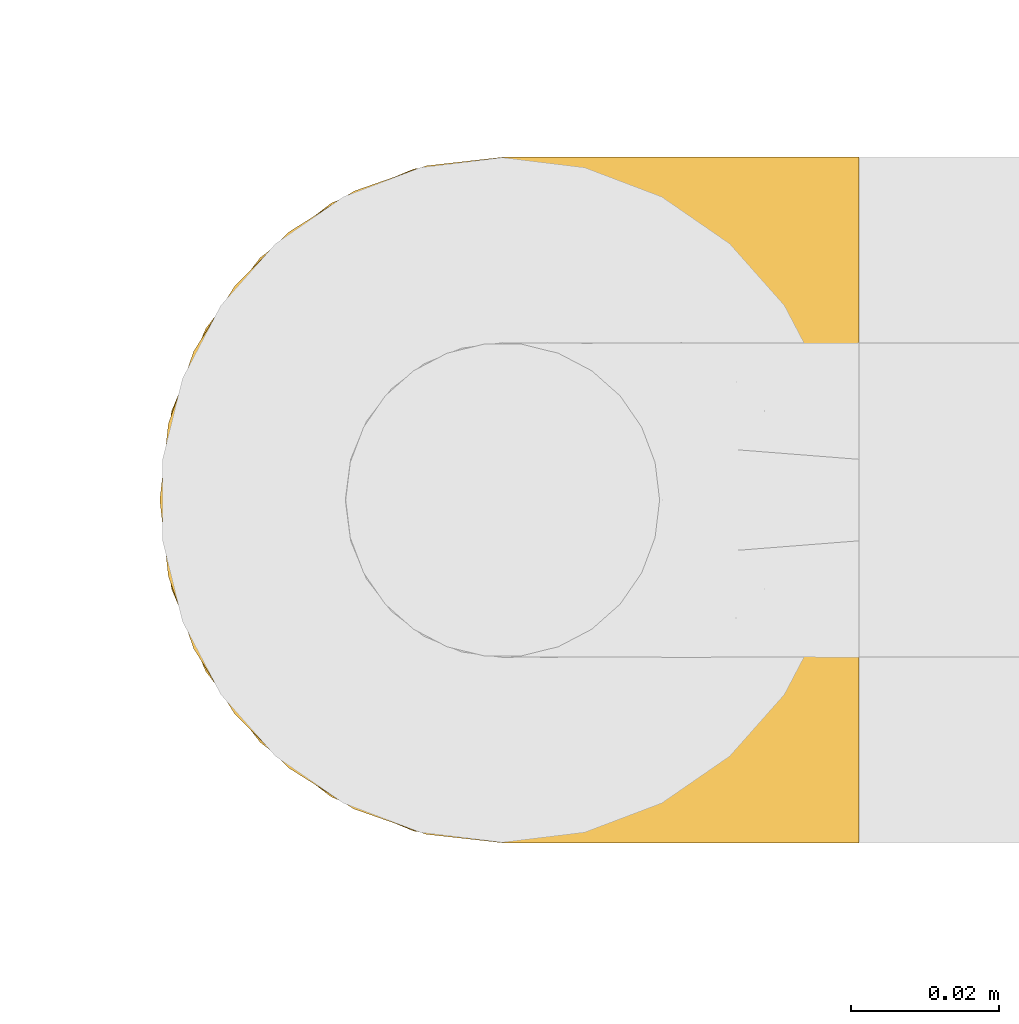
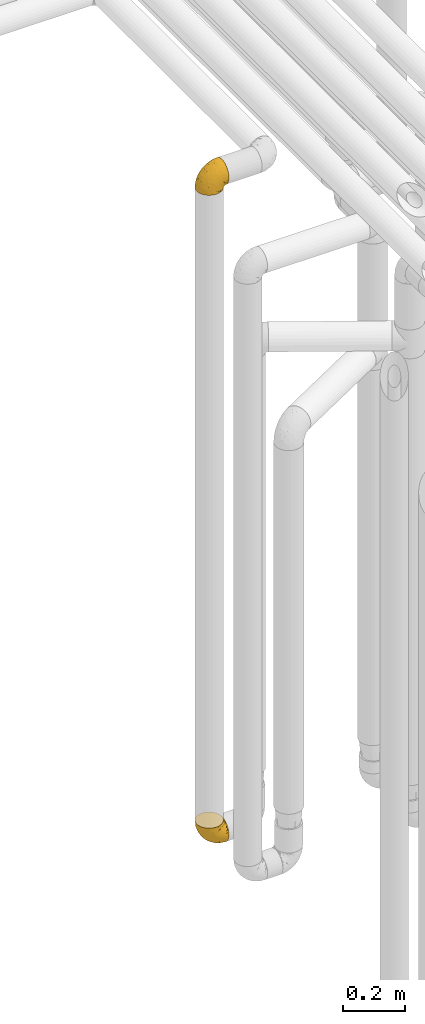
# One storey, part 176 of 827: 2 coverings.
"""IFC2X3 building model written with IfcOpenShell, lengths in millimetres."""

from ifc_helpers import new_model, entity, si_unit, converted_unit, derived_unit, direction, frame, origin, place, context, subcontext, project, spatial, faceted_brep, element, save


model = new_model("IFC2X3")

# Units and contexts
model_context = context("Model", 3, precision=0.01, world=origin(), true_north=direction((6.12303176911189e-17, 1.0)))
body_context = subcontext(model_context, "Body", "Model", "MODEL_VIEW")
ifc_project = project(units=[si_unit("LENGTHUNIT", "METRE", prefix="MILLI"), si_unit("AREAUNIT", "SQUARE_METRE"), si_unit("VOLUMEUNIT", "CUBIC_METRE"), converted_unit("PLANEANGLEUNIT", "DEGREE", entity("IfcRatioMeasure", 0.0174532925199433), si_unit("PLANEANGLEUNIT", "RADIAN"), dimensions=[0, 0, 0, 0, 0, 0, 0]), si_unit("MASSUNIT", "GRAM", prefix="KILO"), derived_unit("MASSDENSITYUNIT", [(si_unit("MASSUNIT", "GRAM", prefix="KILO"), 1), (si_unit("LENGTHUNIT", "METRE"), -3)]), derived_unit("MOMENTOFINERTIAUNIT", [(si_unit("LENGTHUNIT", "METRE"), 4)]), si_unit("TIMEUNIT", "SECOND"), si_unit("FREQUENCYUNIT", "HERTZ"), si_unit("THERMODYNAMICTEMPERATUREUNIT", "DEGREE_CELSIUS"), derived_unit("THERMALTRANSMITTANCEUNIT", [(si_unit("MASSUNIT", "GRAM", prefix="KILO"), 1), (si_unit("THERMODYNAMICTEMPERATUREUNIT", "KELVIN"), -1), (si_unit("TIMEUNIT", "SECOND"), -3)]), derived_unit("VOLUMETRICFLOWRATEUNIT", [(si_unit("LENGTHUNIT", "METRE"), 3), (si_unit("TIMEUNIT", "SECOND"), -1)]), derived_unit("MASSFLOWRATEUNIT", [(si_unit("MASSUNIT", "GRAM", prefix="KILO"), 1), (si_unit("TIMEUNIT", "SECOND"), -1)]), derived_unit("ROTATIONALFREQUENCYUNIT", [(si_unit("TIMEUNIT", "SECOND"), -1)]), si_unit("ELECTRICCURRENTUNIT", "AMPERE"), si_unit("ELECTRICVOLTAGEUNIT", "VOLT"), si_unit("POWERUNIT", "WATT"), si_unit("FORCEUNIT", "NEWTON", prefix="KILO"), si_unit("ILLUMINANCEUNIT", "LUX"), si_unit("LUMINOUSFLUXUNIT", "LUMEN"), si_unit("LUMINOUSINTENSITYUNIT", "CANDELA"), derived_unit("USERDEFINED", [(si_unit("MASSUNIT", "GRAM", prefix="KILO"), -1), (si_unit("LENGTHUNIT", "METRE"), -2), (si_unit("TIMEUNIT", "SECOND"), 3), (si_unit("LUMINOUSFLUXUNIT", "LUMEN"), 1)]), derived_unit("LINEARVELOCITYUNIT", [(si_unit("LENGTHUNIT", "METRE"), 1), (si_unit("TIMEUNIT", "SECOND"), -1)]), si_unit("PRESSUREUNIT", "PASCAL"), derived_unit("USERDEFINED", [(si_unit("LENGTHUNIT", "METRE"), -2), (si_unit("MASSUNIT", "GRAM", prefix="KILO"), 1), (si_unit("TIMEUNIT", "SECOND"), -2)]), derived_unit("LINEARFORCEUNIT", [(si_unit("MASSUNIT", "GRAM", prefix="KILO"), 1), (si_unit("LENGTHUNIT", "METRE"), 1), (si_unit("TIMEUNIT", "SECOND"), -2), (si_unit("LENGTHUNIT", "METRE"), -1)]), derived_unit("PLANARFORCEUNIT", [(si_unit("MASSUNIT", "GRAM", prefix="KILO"), 1), (si_unit("LENGTHUNIT", "METRE"), 1), (si_unit("TIMEUNIT", "SECOND"), -2), (si_unit("LENGTHUNIT", "METRE"), -2)])], contexts=[model_context])

# Site, building, storey
site_placement = place(None, origin())
site = spatial("IfcSite", under=ifc_project, at=site_placement, CompositionType="ELEMENT")
building_placement = place(site_placement, origin())
building = spatial("IfcBuilding", under=site, at=building_placement, CompositionType="ELEMENT")
storey_placement = place(building_placement, frame((0.0, 0.0, 28200.0)))
storey = spatial("IfcBuildingStorey", under=building, at=storey_placement, Name="08", CompositionType="ELEMENT", Elevation=28200.0)

# Coverings
covering_1_placement = place(storey_placement, frame((35072.24, 12958.41, 2950.4)))
element("IfcCovering", 1, at=covering_1_placement, inside=storey, Name=":ADSK_", ObjectType=":ADSK_", PredefinedType="INSULATION", context=body_context, shape_type="Brep", body=[
    faceted_brep([(18.98, 11.68, 1.6), (11.67, 19.0, 1.6), (6.17, 27.76, 1.6), (2.75, 37.52, 1.6), (1.6, 47.8, 1.6), (2.75, 58.08, 1.6), (6.17, 67.85, 1.6), (11.68, 76.61, 1.6), (19.0, 83.92, 1.6), (27.76, 89.42, 1.6), (37.52, 92.84, 1.6), (47.8, 94.0, 1.6), (51.94, 93.53, 1.6), (55.01, 93.18, 1.6), (58.08, 92.84, 1.6), (62.96, 91.13, 1.6), (67.85, 89.42, 1.6), (72.23, 86.66, 1.6), (76.61, 83.91, 1.6), (80.26, 80.25, 1.6), (83.92, 76.59, 1.6), (89.42, 67.83, 1.6), (91.13, 62.95, 1.6), (92.84, 58.07, 1.6), (94.0, 47.8, 1.6), (92.84, 37.51, 1.6), (91.13, 32.63, 1.6), (89.42, 27.74, 1.6), (83.91, 18.98, 1.6), (80.25, 15.33, 1.6), (76.59, 11.67, 1.6), (72.21, 8.92, 1.6), (67.83, 6.17, 1.6), (62.95, 4.46, 1.6), (58.07, 2.75, 1.6), (55.0, 2.41, 1.6), (51.94, 2.06, 1.6), (47.8, 1.6, 1.6), (37.51, 2.75, 1.6), (27.74, 6.17, 1.6), (95.8, 47.8, 3.4), (95.8, 59.75, 4.97), (95.8, 70.9, 9.58), (95.8, 75.68, 13.26), (95.8, 80.46, 16.93), (95.8, 84.13, 21.71), (95.8, 87.81, 26.5), (95.8, 90.11, 32.07), (95.8, 92.42, 37.64), (95.8, 92.9, 41.25), (95.8, 93.17, 43.34), (95.8, 93.45, 45.42), (95.8, 94.0, 49.6), (95.8, 92.42, 61.55), (95.8, 87.81, 72.7), (95.8, 80.46, 82.26), (95.8, 70.9, 89.61), (95.8, 59.75, 94.22), (95.8, 47.8, 95.8), (95.8, 35.84, 94.22), (95.8, 24.7, 89.61), (95.8, 15.13, 82.26), (95.8, 7.78, 72.7), (95.8, 3.17, 61.55), (95.8, 1.6, 49.6), (95.8, 2.14, 45.42), (95.8, 2.69, 41.25), (95.8, 3.17, 37.64), (95.8, 5.48, 32.07), (95.8, 7.78, 26.5), (95.8, 11.46, 21.71), (95.8, 15.13, 16.93), (95.8, 19.91, 13.26), (95.8, 24.7, 9.58), (95.8, 35.84, 4.97), (60.58, 23.61, 81.55), (74.11, 31.99, 90.4), (51.59, 35.87, 83.0), (66.69, 47.8, 91.18), (76.19, 40.43, 93.13), (84.43, 47.8, 94.0), (31.2, 31.83, 66.19), (42.88, 23.37, 70.92), (79.41, 21.41, 85.95), (60.7, 3.07, 49.74), (61.85, 1.6, 35.54), (65.75, 1.6, 38.14), (69.64, 1.6, 40.74), (73.53, 1.6, 43.34), (77.43, 1.6, 45.94), (74.59, 13.45, 77.59), (54.72, 15.25, 71.17), (64.18, 8.07, 65.81), (37.94, 16.0, 59.03), (25.89, 17.34, 45.85), (34.73, 10.58, 45.79), (42.89, 5.34, 41.42), (49.83, 2.39, 34.51), (48.58, 8.36, 56.04), (22.41, 10.04, 15.15), (78.69, 2.59, 56.51), (81.64, 6.28, 68.39), (6.22, 34.28, 23.33), (12.11, 38.73, 42.86), (14.81, 27.25, 39.42), (21.61, 29.88, 53.58), (22.41, 38.6, 59.17), (30.12, 23.44, 59.06), (10.01, 25.25, 22.63), (15.36, 17.23, 20.55), (3.39, 47.8, 12.96), (19.59, 47.8, 56.96), (30.01, 47.8, 67.38), (41.19, 2.53, 18.72), (48.54, 1.6, 5.33), (49.28, 1.6, 9.07), (49.82, 1.6, 11.79), (50.37, 1.6, 14.51), (50.91, 1.6, 17.24), (51.45, 1.6, 19.96), (31.61, 5.71, 21.03), (80.15, 1.6, 46.48), (82.88, 1.6, 47.03), (85.6, 1.6, 47.57), (88.32, 1.6, 48.11), (90.19, 1.6, 48.48), (92.06, 1.6, 48.85), (6.21, 47.8, 30.7), (54.05, 1.6, 23.86), (56.65, 1.6, 27.75), (59.25, 1.6, 31.64), (24.66, 11.89, 31.26), (40.43, 47.8, 77.8), (35.17, 39.69, 72.75), (12.9, 47.8, 43.83), (53.56, 47.8, 84.49), (85.34, 13.84, 14.58), (78.44, 9.16, 16.17), (84.37, 15.79, 10.82), (89.05, 25.75, 4.64), (82.76, 16.09, 7.71), (86.31, 7.51, 25.13), (83.73, 3.99, 32.66), (77.31, 2.66, 34.94), (87.78, 3.16, 36.76), (87.91, 2.35, 40.48), (81.29, 2.23, 39.25), (93.97, 38.35, 3.69), (70.76, 6.18, 13.99), (63.67, 2.7, 21.85), (62.62, 2.93, 17.93), (90.64, 16.01, 15.11), (84.08, 9.08, 21.14), (76.28, 9.3, 12.7), (77.45, 11.68, 7.21), (88.72, 4.65, 32.27), (71.28, 3.65, 25.68), (68.09, 3.61, 22.18), (91.07, 12.8, 18.79), (57.47, 2.43, 10.12), (70.34, 6.83, 9.47), (91.35, 21.65, 10.45), (62.99, 3.7, 11.29), (94.52, 47.8, 2.87), (76.47, 3.37, 31.16), (69.96, 7.03, 6.31), (89.86, 7.87, 25.62), (78.94, 7.26, 21.18), (73.51, 3.41, 28.81), (89.62, 23.81, 7.45), (84.09, 86.5, 21.14), (86.3, 88.08, 25.13), (91.06, 82.79, 18.79), (88.32, 94.0, 48.11), (92.06, 94.0, 48.85), (82.88, 94.0, 47.03), (85.6, 94.0, 47.57), (93.97, 57.24, 3.69), (89.63, 71.76, 7.44), (50.37, 94.0, 14.51), (49.82, 94.0, 11.79), (48.54, 94.0, 5.33), (49.28, 94.0, 9.07), (82.77, 79.49, 7.71), (70.36, 88.75, 9.47), (77.31, 92.93, 34.94), (76.47, 92.22, 31.16), (69.64, 94.0, 40.74), (65.75, 94.0, 38.14), (87.78, 92.43, 36.76), (87.91, 93.24, 40.48), (89.06, 69.82, 4.63), (90.65, 79.57, 15.11), (85.35, 81.74, 14.58), (73.53, 94.0, 43.34), (77.43, 94.0, 45.94), (81.29, 93.36, 39.25), (77.46, 83.9, 7.21), (76.29, 86.28, 12.69), (57.47, 93.16, 10.14), (63.71, 92.88, 21.81), (68.11, 91.98, 22.19), (70.77, 89.41, 14.0), (71.31, 91.93, 25.69), (78.46, 86.42, 16.17), (69.52, 88.82, 6.66), (62.64, 92.66, 17.92), (91.35, 73.93, 10.45), (59.25, 94.0, 31.64), (84.6, 79.5, 10.64), (62.98, 91.89, 11.31), (51.45, 94.0, 19.96), (54.05, 94.0, 23.86), (56.65, 94.0, 27.75), (83.73, 91.6, 32.66), (80.15, 94.0, 46.48), (88.72, 90.94, 32.27), (61.85, 94.0, 35.54), (73.56, 92.16, 28.77), (78.96, 88.32, 21.17), (91.36, 86.13, 23.36), (50.91, 94.0, 17.24), (62.87, 93.2, 47.58), (76.19, 55.16, 93.13), (73.57, 82.02, 77.44), (56.07, 84.29, 66.78), (49.77, 76.94, 71.68), (44.73, 68.33, 74.96), (60.58, 71.98, 81.55), (47.64, 92.52, 36.7), (78.32, 92.9, 56.9), (51.59, 59.72, 83.0), (74.11, 63.6, 90.4), (76.04, 88.89, 67.83), (79.41, 74.18, 85.95), (14.82, 68.35, 39.41), (6.22, 61.33, 23.33), (12.12, 56.86, 42.87), (23.51, 68.62, 53.92), (31.2, 63.76, 66.19), (34.96, 72.19, 64.12), (33.86, 88.69, 33.13), (38.94, 92.19, 23.1), (30.23, 89.75, 16.98), (35.17, 55.9, 72.75), (15.85, 77.99, 23.77), (22.59, 85.21, 18.41), (21.56, 74.99, 43.7), (55.94, 90.23, 54.53), (20.67, 59.86, 55.72), (9.19, 70.75, 17.73), (25.79, 81.72, 38.98), (41.16, 86.53, 50.28), (37.95, 79.6, 59.02)], [[[0, 1, 2, 3, 4, 5, 6, 7, 8, 9, 10, 11, 12, 13, 14, 15, 16, 17, 18, 19, 20, 21, 22, 23, 24, 25, 26, 27, 28, 29, 30, 31, 32, 33, 34, 35, 36, 37, 38, 39]], [[40, 41, 42, 43, 44, 45, 46, 47, 48, 49, 50, 51, 52, 53, 54, 55, 56, 57, 58, 59, 60, 61, 62, 63, 64, 65, 66, 67, 68, 69, 70, 71, 72, 73, 74]], [[75, 76, 77]], [[78, 79, 80]], [[77, 81, 82]], [[76, 75, 83]], [[84, 85, 86, 87, 88, 89]], [[90, 91, 92]], [[76, 60, 59]], [[93, 94, 95]], [[90, 62, 61]], [[83, 61, 60]], [[96, 97, 84]], [[98, 93, 95]], [[0, 39, 99]], [[100, 84, 89]], [[62, 101, 63]], [[2, 102, 3]], [[92, 84, 100]], [[103, 102, 104]], [[103, 105, 106]], [[93, 107, 94]], [[1, 108, 2]], [[92, 101, 90]], [[108, 1, 109]], [[102, 110, 3]], [[93, 82, 107]], [[102, 108, 104]], [[111, 106, 112]], [[109, 0, 99]], [[113, 37, 114, 115, 116, 117, 118, 119]], [[120, 38, 113]], [[100, 89, 121, 122, 123, 124, 125, 126, 64]], [[127, 102, 103]], [[97, 119, 128, 129, 130, 85]], [[99, 120, 131]], [[132, 133, 77]], [[59, 80, 79]], [[1, 0, 109]], [[98, 84, 92]], [[94, 109, 131]], [[120, 39, 38]], [[93, 91, 82]], [[104, 94, 105]], [[97, 113, 119]], [[95, 120, 96]], [[83, 90, 61]], [[91, 93, 98]], [[64, 63, 100]], [[100, 63, 101]], [[77, 76, 79]], [[133, 106, 81]], [[84, 97, 85]], [[113, 96, 120]], [[113, 97, 96]], [[37, 113, 38]], [[110, 102, 127]], [[110, 4, 3]], [[103, 111, 134, 127]], [[90, 75, 91]], [[82, 81, 107]], [[91, 75, 82]], [[77, 82, 75]], [[76, 83, 60]], [[90, 83, 75]], [[105, 107, 81]], [[94, 131, 95]], [[105, 94, 107]], [[109, 94, 104]], [[120, 95, 131]], [[98, 95, 96]], [[84, 98, 96]], [[98, 92, 91]], [[106, 105, 81]], [[103, 104, 105]], [[112, 106, 133]], [[103, 106, 111]], [[112, 133, 132]], [[81, 77, 133]], [[77, 78, 135, 132]], [[120, 99, 39]], [[109, 99, 131]], [[59, 58, 80]], [[59, 79, 76]], [[90, 101, 62]], [[100, 101, 92]], [[2, 108, 102]], [[109, 104, 108]], [[78, 77, 79]], [[136, 137, 138]], [[27, 139, 140]], [[141, 142, 143]], [[144, 145, 121]], [[146, 89, 88]], [[147, 139, 25]], [[148, 149, 150]], [[136, 151, 152]], [[147, 40, 74]], [[24, 147, 25]], [[140, 153, 154]], [[33, 116, 34]], [[73, 72, 151]], [[114, 37, 36, 35, 34, 116, 115]], [[146, 155, 144]], [[156, 85, 130]], [[157, 149, 148]], [[151, 158, 152]], [[117, 33, 159]], [[29, 154, 160]], [[161, 74, 73]], [[162, 128, 119]], [[66, 65, 64, 126, 125, 124, 123, 122, 67]], [[163, 147, 24]], [[27, 140, 28]], [[149, 129, 150]], [[139, 27, 26, 25]], [[68, 144, 69]], [[129, 128, 150]], [[164, 87, 86]], [[130, 129, 149]], [[122, 145, 67]], [[154, 153, 148]], [[162, 119, 159]], [[165, 30, 160]], [[150, 160, 148]], [[128, 162, 150]], [[30, 165, 31]], [[145, 144, 68]], [[89, 146, 144]], [[87, 164, 143]], [[166, 155, 142]], [[88, 87, 143]], [[162, 160, 150]], [[160, 30, 29]], [[154, 29, 28]], [[140, 154, 28]], [[160, 154, 148]], [[140, 137, 153]], [[157, 148, 153]], [[156, 130, 157]], [[153, 137, 157]], [[157, 137, 156]], [[167, 137, 136]], [[168, 85, 156]], [[152, 168, 167]], [[167, 168, 156]], [[164, 152, 141]], [[71, 158, 72]], [[152, 167, 136]], [[88, 142, 146]], [[144, 155, 69]], [[146, 142, 155]], [[70, 166, 71]], [[142, 141, 166]], [[70, 69, 155]], [[141, 158, 71]], [[161, 73, 151]], [[138, 137, 140]], [[161, 136, 169]], [[136, 161, 151]], [[74, 161, 169]], [[152, 158, 141]], [[151, 72, 158]], [[168, 152, 164]], [[137, 167, 156]], [[164, 86, 168]], [[85, 168, 86]], [[116, 33, 117]], [[130, 149, 157]], [[67, 145, 68]], [[121, 89, 144]], [[145, 122, 121]], [[40, 147, 163]], [[169, 147, 74]], [[159, 33, 32]], [[162, 159, 32]], [[159, 119, 118, 117]], [[139, 147, 169]], [[139, 169, 138]], [[162, 32, 31]], [[141, 143, 164]], [[88, 143, 142]], [[71, 166, 141]], [[155, 166, 70]], [[139, 138, 140]], [[169, 136, 138]], [[160, 162, 165]], [[162, 31, 165]], [[170, 171, 172]], [[173, 174, 52, 51, 50, 49, 48, 175, 176]], [[177, 178, 41]], [[179, 15, 180]], [[12, 11, 181, 182, 180, 14, 13]], [[183, 21, 20]], [[19, 18, 184]], [[185, 186, 187]], [[186, 188, 187]], [[43, 172, 44]], [[189, 190, 47]], [[23, 22, 21, 191]], [[170, 192, 193]], [[40, 163, 177]], [[194, 195, 196]], [[24, 23, 177]], [[197, 198, 183]], [[199, 15, 179]], [[47, 46, 189]], [[200, 201, 202]], [[201, 203, 204]], [[205, 206, 184]], [[207, 41, 178]], [[16, 15, 199]], [[14, 180, 15]], [[202, 201, 198]], [[208, 201, 200]], [[163, 24, 177]], [[48, 47, 190]], [[196, 195, 189]], [[197, 184, 202]], [[204, 193, 209]], [[210, 211, 212]], [[206, 212, 213]], [[205, 17, 210]], [[184, 206, 202]], [[210, 212, 206]], [[185, 194, 214]], [[189, 215, 190]], [[216, 45, 214]], [[186, 171, 170]], [[189, 216, 196]], [[197, 20, 19]], [[194, 185, 187]], [[197, 183, 20]], [[184, 197, 19]], [[197, 202, 198]], [[206, 200, 202]], [[204, 183, 198]], [[201, 208, 203]], [[203, 208, 217]], [[204, 198, 201]], [[217, 188, 218]], [[193, 219, 170]], [[171, 186, 185]], [[170, 218, 186]], [[170, 219, 218]], [[42, 207, 192]], [[171, 220, 172]], [[216, 189, 46]], [[214, 194, 196]], [[44, 220, 45]], [[214, 196, 216]], [[216, 46, 45]], [[214, 45, 220]], [[192, 43, 42]], [[204, 203, 219]], [[207, 193, 192]], [[209, 193, 178]], [[41, 207, 42]], [[193, 207, 178]], [[43, 192, 172]], [[170, 172, 192]], [[204, 219, 193]], [[219, 203, 218]], [[217, 218, 203]], [[188, 186, 218]], [[206, 213, 200]], [[208, 200, 213]], [[199, 210, 16]], [[215, 189, 195]], [[215, 175, 190]], [[175, 48, 190]], [[199, 179, 221, 211]], [[210, 199, 211]], [[23, 191, 177]], [[40, 177, 41]], [[178, 177, 191]], [[21, 183, 191]], [[209, 191, 183]], [[205, 18, 17]], [[17, 16, 210]], [[171, 185, 214]], [[172, 220, 44]], [[214, 220, 171]], [[191, 209, 178]], [[204, 209, 183]], [[206, 205, 210]], [[18, 205, 184]], [[222, 195, 194, 187, 188, 217]], [[57, 223, 80]], [[224, 225, 226]], [[226, 227, 228]], [[229, 217, 208, 213, 212, 211]], [[230, 52, 174, 173, 176, 175, 215, 195]], [[231, 232, 228]], [[231, 78, 223]], [[223, 57, 232]], [[224, 233, 225]], [[233, 54, 53]], [[234, 232, 56]], [[56, 55, 234]], [[234, 224, 228]], [[235, 236, 237]], [[224, 55, 54]], [[238, 239, 240]], [[52, 230, 53]], [[241, 242, 243]], [[227, 244, 231]], [[11, 10, 242]], [[236, 6, 5]], [[7, 245, 8]], [[8, 246, 9]], [[238, 247, 235]], [[222, 229, 248]], [[242, 211, 221, 179, 180, 182, 181, 11]], [[233, 53, 230]], [[111, 112, 249]], [[250, 6, 236]], [[246, 251, 241]], [[6, 250, 7]], [[127, 236, 110]], [[248, 229, 252]], [[246, 8, 245]], [[235, 245, 250]], [[236, 5, 110]], [[235, 249, 238]], [[237, 236, 127]], [[243, 9, 246]], [[252, 229, 241]], [[56, 232, 57]], [[222, 230, 195]], [[225, 248, 252]], [[248, 233, 230]], [[54, 233, 224]], [[231, 228, 227]], [[244, 132, 231]], [[248, 225, 233]], [[226, 225, 253]], [[235, 250, 236]], [[245, 7, 250]], [[251, 246, 245]], [[243, 246, 241]], [[247, 245, 235]], [[252, 251, 253]], [[229, 222, 217]], [[230, 222, 248]], [[5, 4, 110]], [[237, 127, 134, 111]], [[238, 249, 239]], [[224, 234, 55]], [[232, 234, 228]], [[242, 241, 229]], [[10, 9, 243]], [[211, 242, 229]], [[10, 243, 242]], [[80, 223, 78]], [[80, 58, 57]], [[231, 223, 232]], [[227, 240, 239]], [[224, 226, 228]], [[240, 226, 253]], [[227, 239, 244]], [[226, 240, 227]], [[251, 247, 253]], [[240, 253, 247]], [[249, 235, 237]], [[237, 111, 249]], [[112, 132, 244]], [[112, 244, 249]], [[78, 231, 132, 135]], [[249, 244, 239]], [[247, 238, 240]], [[245, 247, 251]], [[251, 252, 241]], [[225, 252, 253]]]),
])
covering_2_placement = place(storey_placement, frame((35072.24, 12958.41, 352.2)))
element("IfcCovering", 2, at=covering_2_placement, inside=storey, Name=":ADSK_", ObjectType=":ADSK_", PredefinedType="INSULATION", context=body_context, shape_type="Brep", body=[
    faceted_brep([(95.8, 11.68, 18.98), (95.8, 19.0, 11.67), (95.8, 27.76, 6.17), (95.8, 37.52, 2.75), (95.8, 47.8, 1.6), (95.8, 58.08, 2.75), (95.8, 67.85, 6.17), (95.8, 76.61, 11.68), (95.8, 83.92, 19.0), (95.8, 89.42, 27.76), (95.8, 92.84, 37.52), (95.8, 94.0, 47.8), (95.8, 93.53, 51.94), (95.8, 93.18, 55.01), (95.8, 92.84, 58.08), (95.8, 91.13, 62.96), (95.8, 89.42, 67.85), (95.8, 86.66, 72.23), (95.8, 83.91, 76.61), (95.8, 80.25, 80.26), (95.8, 76.59, 83.92), (95.8, 67.83, 89.42), (95.8, 62.95, 91.13), (95.8, 58.07, 92.84), (95.8, 47.8, 94.0), (95.8, 37.51, 92.84), (95.8, 32.63, 91.13), (95.8, 27.74, 89.42), (95.8, 18.98, 83.91), (95.8, 15.33, 80.25), (95.8, 11.67, 76.59), (95.8, 8.92, 72.21), (95.8, 6.17, 67.83), (95.8, 4.46, 62.95), (95.8, 2.75, 58.07), (95.8, 2.41, 55.0), (95.8, 2.06, 51.94), (95.8, 1.6, 47.8), (95.8, 2.75, 37.51), (95.8, 6.17, 27.74), (94.0, 47.8, 95.8), (92.42, 59.75, 95.8), (87.81, 70.9, 95.8), (84.13, 75.68, 95.8), (80.46, 80.46, 95.8), (75.68, 84.13, 95.8), (70.9, 87.81, 95.8), (65.32, 90.11, 95.8), (59.75, 92.42, 95.8), (56.14, 92.9, 95.8), (54.06, 93.17, 95.8), (51.97, 93.45, 95.8), (47.8, 94.0, 95.8), (35.84, 92.42, 95.8), (24.7, 87.81, 95.8), (15.13, 80.46, 95.8), (7.78, 70.9, 95.8), (3.17, 59.75, 95.8), (1.6, 47.8, 95.8), (3.17, 35.84, 95.8), (7.78, 24.7, 95.8), (15.13, 15.13, 95.8), (24.7, 7.78, 95.8), (35.84, 3.17, 95.8), (47.8, 1.6, 95.8), (51.97, 2.14, 95.8), (56.14, 2.69, 95.8), (59.75, 3.17, 95.8), (65.32, 5.48, 95.8), (70.9, 7.78, 95.8), (75.68, 11.46, 95.8), (80.46, 15.13, 95.8), (84.13, 19.91, 95.8), (87.81, 24.7, 95.8), (92.42, 35.84, 95.8), (15.84, 23.61, 60.58), (6.99, 31.99, 74.11), (14.39, 35.87, 51.59), (6.21, 47.8, 66.69), (4.26, 40.43, 76.19), (3.39, 47.8, 84.43), (31.2, 31.83, 31.2), (26.47, 23.37, 42.88), (11.44, 21.41, 79.41), (47.66, 3.07, 60.7), (61.85, 1.6, 61.85), (59.25, 1.6, 65.75), (56.65, 1.6, 69.64), (54.05, 1.6, 73.53), (51.45, 1.6, 77.43), (19.8, 13.45, 74.59), (26.22, 15.25, 54.72), (31.58, 8.07, 64.18), (38.36, 16.0, 37.94), (51.54, 17.34, 25.89), (51.6, 10.58, 34.73), (55.97, 5.34, 42.89), (62.88, 2.39, 49.83), (41.35, 8.36, 48.58), (82.24, 10.04, 22.41), (40.88, 2.59, 78.69), (29.0, 6.28, 81.64), (74.06, 34.28, 6.22), (54.53, 38.73, 12.11), (57.98, 27.25, 14.81), (43.81, 29.88, 21.61), (38.22, 38.6, 22.41), (38.33, 23.44, 30.12), (74.76, 25.25, 10.01), (76.85, 17.23, 15.36), (84.43, 47.8, 3.39), (40.43, 47.8, 19.59), (30.01, 47.8, 30.01), (78.67, 2.53, 41.19), (92.06, 1.6, 48.54), (88.32, 1.6, 49.28), (85.6, 1.6, 49.82), (82.88, 1.6, 50.37), (80.15, 1.6, 50.91), (77.43, 1.6, 51.45), (76.36, 5.71, 31.61), (50.91, 1.6, 80.15), (50.37, 1.6, 82.88), (49.82, 1.6, 85.6), (49.28, 1.6, 88.32), (48.91, 1.6, 90.19), (48.54, 1.6, 92.06), (66.69, 47.8, 6.21), (73.53, 1.6, 54.05), (69.64, 1.6, 56.65), (65.75, 1.6, 59.25), (66.13, 11.89, 24.66), (19.59, 47.8, 40.43), (24.64, 39.69, 35.17), (53.56, 47.8, 12.9), (12.9, 47.8, 53.56), (82.81, 13.84, 85.34), (81.22, 9.16, 78.44), (86.57, 15.79, 84.37), (92.75, 25.75, 89.05), (89.68, 16.09, 82.76), (72.26, 7.51, 86.31), (64.73, 3.99, 83.73), (62.45, 2.66, 77.31), (60.63, 3.16, 87.78), (56.91, 2.35, 87.91), (58.14, 2.23, 81.29), (93.7, 38.35, 93.97), (83.4, 6.18, 70.76), (75.54, 2.7, 63.67), (79.46, 2.93, 62.62), (82.28, 16.01, 90.64), (76.25, 9.08, 84.08), (90.18, 11.68, 77.45), (87.92, 6.83, 70.34), (65.12, 4.65, 88.72), (71.71, 3.65, 71.28), (75.21, 3.61, 68.09), (78.6, 12.8, 91.07), (87.27, 2.43, 57.47), (86.94, 21.65, 91.35), (86.1, 3.7, 62.99), (94.52, 47.8, 94.52), (66.23, 3.37, 76.47), (84.69, 9.3, 76.28), (91.08, 7.03, 69.96), (71.77, 7.87, 89.86), (76.21, 7.26, 78.94), (68.59, 3.41, 73.51), (89.94, 23.81, 89.62), (76.25, 86.5, 84.09), (72.26, 88.08, 86.3), (78.6, 82.79, 91.06), (49.28, 94.0, 88.32), (48.54, 94.0, 92.06), (50.37, 94.0, 82.88), (49.82, 94.0, 85.6), (93.7, 57.24, 93.97), (89.95, 71.76, 89.63), (82.88, 94.0, 50.37), (85.6, 94.0, 49.82), (92.06, 94.0, 48.54), (88.32, 94.0, 49.28), (89.68, 79.49, 82.77), (87.92, 88.75, 70.36), (62.45, 92.93, 77.31), (66.24, 92.22, 76.47), (56.65, 94.0, 69.64), (59.25, 94.0, 65.75), (60.63, 92.43, 87.78), (56.91, 93.24, 87.91), (92.76, 69.82, 89.06), (82.28, 79.57, 90.65), (82.81, 81.74, 85.35), (54.05, 94.0, 73.53), (51.45, 94.0, 77.43), (58.14, 93.36, 81.29), (90.18, 83.9, 77.46), (84.7, 86.28, 76.29), (87.25, 93.16, 57.47), (75.58, 92.88, 63.71), (75.2, 91.98, 68.11), (83.39, 89.41, 70.77), (71.7, 91.93, 71.31), (81.22, 86.42, 78.46), (90.73, 88.82, 69.52), (79.47, 92.66, 62.64), (86.94, 73.93, 91.35), (65.75, 94.0, 59.25), (86.75, 79.5, 84.6), (86.08, 91.89, 62.98), (77.43, 94.0, 51.45), (73.53, 94.0, 54.05), (69.64, 94.0, 56.65), (64.73, 91.6, 83.73), (50.91, 94.0, 80.15), (65.12, 90.94, 88.72), (61.85, 94.0, 61.85), (68.62, 92.16, 73.56), (76.22, 88.32, 78.96), (74.03, 86.13, 91.36), (80.15, 94.0, 50.91), (49.81, 93.2, 62.87), (4.26, 55.16, 76.19), (19.95, 82.02, 73.57), (30.61, 84.29, 56.07), (25.71, 76.94, 49.77), (22.43, 68.33, 44.73), (15.85, 71.98, 60.58), (60.69, 92.52, 47.64), (40.49, 92.9, 78.32), (14.39, 59.72, 51.59), (6.99, 63.6, 74.11), (29.56, 88.89, 76.04), (11.45, 74.18, 79.41), (57.98, 68.35, 14.82), (74.06, 61.33, 6.22), (54.52, 56.86, 12.12), (43.47, 68.62, 23.51), (31.2, 63.76, 31.2), (33.27, 72.19, 34.96), (64.26, 88.69, 33.86), (74.29, 92.19, 38.94), (80.41, 89.75, 30.23), (24.64, 55.9, 35.17), (73.62, 77.99, 15.85), (78.98, 85.21, 22.59), (53.69, 74.99, 21.56), (42.86, 90.23, 55.94), (41.67, 59.86, 20.67), (79.66, 70.75, 9.19), (58.41, 81.72, 25.79), (47.11, 86.53, 41.16), (38.37, 79.6, 37.95)], [[[0, 1, 2, 3, 4, 5, 6, 7, 8, 9, 10, 11, 12, 13, 14, 15, 16, 17, 18, 19, 20, 21, 22, 23, 24, 25, 26, 27, 28, 29, 30, 31, 32, 33, 34, 35, 36, 37, 38, 39]], [[40, 41, 42, 43, 44, 45, 46, 47, 48, 49, 50, 51, 52, 53, 54, 55, 56, 57, 58, 59, 60, 61, 62, 63, 64, 65, 66, 67, 68, 69, 70, 71, 72, 73, 74]], [[75, 76, 77]], [[78, 79, 80]], [[77, 81, 82]], [[76, 75, 83]], [[84, 85, 86, 87, 88, 89]], [[90, 91, 92]], [[76, 60, 59]], [[93, 94, 95]], [[90, 62, 61]], [[83, 61, 60]], [[96, 97, 84]], [[98, 93, 95]], [[0, 39, 99]], [[100, 84, 89]], [[62, 101, 63]], [[2, 102, 3]], [[92, 84, 100]], [[103, 102, 104]], [[103, 105, 106]], [[93, 107, 94]], [[1, 108, 2]], [[92, 101, 90]], [[108, 1, 109]], [[102, 110, 3]], [[93, 82, 107]], [[102, 108, 104]], [[111, 106, 112]], [[109, 0, 99]], [[113, 37, 114, 115, 116, 117, 118, 119]], [[120, 38, 113]], [[100, 89, 121, 122, 123, 124, 125, 126, 64]], [[127, 102, 103]], [[97, 119, 128, 129, 130, 85]], [[99, 120, 131]], [[132, 133, 77]], [[59, 80, 79]], [[1, 0, 109]], [[98, 84, 92]], [[94, 109, 131]], [[120, 39, 38]], [[93, 91, 82]], [[104, 94, 105]], [[97, 113, 119]], [[95, 120, 96]], [[83, 90, 61]], [[91, 93, 98]], [[64, 63, 100]], [[100, 63, 101]], [[77, 76, 79]], [[133, 106, 81]], [[84, 97, 85]], [[113, 96, 120]], [[113, 97, 96]], [[37, 113, 38]], [[110, 102, 127]], [[110, 4, 3]], [[103, 111, 134, 127]], [[90, 75, 91]], [[82, 81, 107]], [[91, 75, 82]], [[77, 82, 75]], [[76, 83, 60]], [[90, 83, 75]], [[105, 107, 81]], [[94, 131, 95]], [[105, 94, 107]], [[109, 94, 104]], [[120, 95, 131]], [[98, 95, 96]], [[84, 98, 96]], [[98, 92, 91]], [[106, 105, 81]], [[103, 104, 105]], [[133, 132, 112]], [[103, 106, 111]], [[77, 78, 135, 132]], [[106, 133, 112]], [[77, 133, 81]], [[120, 99, 39]], [[109, 99, 131]], [[59, 58, 80]], [[59, 79, 76]], [[90, 101, 62]], [[100, 101, 92]], [[2, 108, 102]], [[109, 104, 108]], [[78, 77, 79]], [[136, 137, 138]], [[27, 139, 140]], [[141, 142, 143]], [[144, 145, 121]], [[146, 89, 88]], [[147, 139, 25]], [[148, 149, 150]], [[136, 151, 152]], [[147, 40, 74]], [[24, 147, 25]], [[153, 148, 154]], [[33, 116, 34]], [[73, 72, 151]], [[114, 37, 36, 35, 34, 116, 115]], [[146, 155, 144]], [[156, 85, 130]], [[157, 149, 148]], [[151, 158, 152]], [[117, 33, 159]], [[29, 153, 154]], [[160, 74, 73]], [[161, 128, 119]], [[66, 65, 64, 126, 125, 124, 123, 122, 67]], [[162, 147, 24]], [[27, 140, 28]], [[149, 129, 150]], [[139, 27, 26, 25]], [[68, 144, 69]], [[129, 128, 150]], [[163, 87, 86]], [[130, 129, 149]], [[122, 145, 67]], [[153, 164, 148]], [[161, 119, 159]], [[165, 30, 154]], [[150, 154, 148]], [[128, 161, 150]], [[30, 165, 31]], [[145, 144, 68]], [[89, 146, 144]], [[87, 163, 143]], [[166, 155, 142]], [[88, 87, 143]], [[161, 154, 150]], [[154, 30, 29]], [[29, 28, 153]], [[28, 140, 153]], [[164, 153, 140]], [[140, 137, 164]], [[157, 148, 164]], [[156, 130, 157]], [[164, 137, 157]], [[157, 137, 156]], [[167, 137, 136]], [[168, 85, 156]], [[152, 168, 167]], [[167, 168, 156]], [[163, 152, 141]], [[71, 158, 72]], [[152, 167, 136]], [[88, 142, 146]], [[144, 155, 69]], [[146, 142, 155]], [[70, 166, 71]], [[142, 141, 166]], [[70, 69, 155]], [[141, 158, 71]], [[160, 73, 151]], [[138, 137, 140]], [[160, 136, 169]], [[136, 160, 151]], [[74, 160, 169]], [[152, 158, 141]], [[151, 72, 158]], [[168, 152, 163]], [[137, 167, 156]], [[163, 86, 168]], [[85, 168, 86]], [[116, 33, 117]], [[130, 149, 157]], [[67, 145, 68]], [[121, 89, 144]], [[145, 122, 121]], [[40, 147, 162]], [[169, 147, 74]], [[159, 33, 32]], [[161, 159, 32]], [[159, 119, 118, 117]], [[139, 147, 169]], [[139, 169, 138]], [[161, 32, 31]], [[141, 143, 163]], [[88, 143, 142]], [[71, 166, 141]], [[155, 166, 70]], [[139, 138, 140]], [[169, 136, 138]], [[154, 161, 165]], [[161, 31, 165]], [[170, 171, 172]], [[173, 174, 52, 51, 50, 49, 48, 175, 176]], [[177, 178, 41]], [[179, 15, 180]], [[12, 11, 181, 182, 180, 14, 13]], [[183, 21, 20]], [[19, 18, 184]], [[185, 186, 187]], [[186, 188, 187]], [[43, 172, 44]], [[189, 190, 47]], [[23, 22, 21, 191]], [[170, 192, 193]], [[40, 162, 177]], [[194, 195, 196]], [[24, 23, 177]], [[197, 198, 183]], [[199, 15, 179]], [[47, 46, 189]], [[200, 201, 202]], [[201, 203, 204]], [[205, 206, 184]], [[207, 41, 178]], [[16, 15, 199]], [[14, 180, 15]], [[202, 201, 198]], [[208, 201, 200]], [[162, 24, 177]], [[48, 47, 190]], [[196, 195, 189]], [[197, 184, 202]], [[204, 193, 209]], [[210, 211, 212]], [[206, 212, 213]], [[205, 17, 210]], [[184, 206, 202]], [[210, 212, 206]], [[185, 194, 214]], [[189, 215, 190]], [[216, 45, 214]], [[186, 171, 170]], [[189, 216, 196]], [[19, 184, 197]], [[194, 185, 187]], [[19, 197, 20]], [[198, 197, 202]], [[183, 20, 197]], [[206, 200, 202]], [[204, 183, 198]], [[201, 208, 203]], [[203, 208, 217]], [[204, 198, 201]], [[217, 188, 218]], [[193, 219, 170]], [[171, 186, 185]], [[170, 218, 186]], [[170, 219, 218]], [[42, 207, 192]], [[171, 220, 172]], [[216, 189, 46]], [[214, 194, 196]], [[44, 220, 45]], [[214, 196, 216]], [[216, 46, 45]], [[214, 45, 220]], [[192, 43, 42]], [[204, 203, 219]], [[207, 193, 192]], [[209, 193, 178]], [[41, 207, 42]], [[193, 207, 178]], [[43, 192, 172]], [[170, 172, 192]], [[204, 219, 193]], [[219, 203, 218]], [[217, 218, 203]], [[188, 186, 218]], [[206, 213, 200]], [[208, 200, 213]], [[199, 210, 16]], [[215, 189, 195]], [[215, 175, 190]], [[175, 48, 190]], [[199, 179, 221, 211]], [[210, 199, 211]], [[23, 191, 177]], [[40, 177, 41]], [[183, 209, 191]], [[183, 191, 21]], [[191, 178, 177]], [[205, 18, 17]], [[17, 16, 210]], [[171, 185, 214]], [[172, 220, 44]], [[214, 220, 171]], [[191, 209, 178]], [[204, 209, 183]], [[206, 205, 210]], [[18, 205, 184]], [[222, 195, 194, 187, 188, 217]], [[57, 223, 80]], [[224, 225, 226]], [[226, 227, 228]], [[229, 217, 208, 213, 212, 211]], [[230, 52, 174, 173, 176, 175, 215, 195]], [[231, 232, 228]], [[231, 78, 223]], [[223, 57, 232]], [[224, 233, 225]], [[233, 54, 53]], [[234, 232, 56]], [[56, 55, 234]], [[234, 224, 228]], [[235, 236, 237]], [[224, 55, 54]], [[238, 239, 240]], [[52, 230, 53]], [[241, 242, 243]], [[227, 244, 231]], [[11, 10, 242]], [[236, 6, 5]], [[7, 245, 8]], [[8, 246, 9]], [[238, 247, 235]], [[222, 229, 248]], [[242, 211, 221, 179, 180, 182, 181, 11]], [[233, 53, 230]], [[111, 112, 249]], [[250, 6, 236]], [[246, 251, 241]], [[6, 250, 7]], [[127, 236, 110]], [[248, 229, 252]], [[246, 8, 245]], [[235, 245, 250]], [[236, 5, 110]], [[235, 249, 238]], [[237, 236, 127]], [[243, 9, 246]], [[252, 229, 241]], [[56, 232, 57]], [[222, 230, 195]], [[225, 248, 252]], [[248, 233, 230]], [[54, 233, 224]], [[231, 228, 227]], [[244, 132, 231]], [[248, 225, 233]], [[226, 225, 253]], [[235, 250, 236]], [[245, 7, 250]], [[251, 246, 245]], [[243, 246, 241]], [[247, 245, 235]], [[252, 251, 253]], [[229, 222, 217]], [[230, 222, 248]], [[5, 4, 110]], [[237, 127, 134, 111]], [[238, 249, 239]], [[224, 234, 55]], [[232, 234, 228]], [[242, 241, 229]], [[10, 9, 243]], [[211, 242, 229]], [[10, 243, 242]], [[80, 223, 78]], [[80, 58, 57]], [[231, 223, 232]], [[227, 240, 239]], [[224, 226, 228]], [[240, 226, 253]], [[227, 239, 244]], [[226, 240, 227]], [[251, 247, 253]], [[240, 253, 247]], [[249, 235, 237]], [[237, 111, 249]], [[112, 132, 244]], [[112, 244, 249]], [[78, 231, 132, 135]], [[249, 244, 239]], [[247, 238, 240]], [[245, 247, 251]], [[251, 252, 241]], [[225, 252, 253]]]),
])

save(model, "model.ifc")
